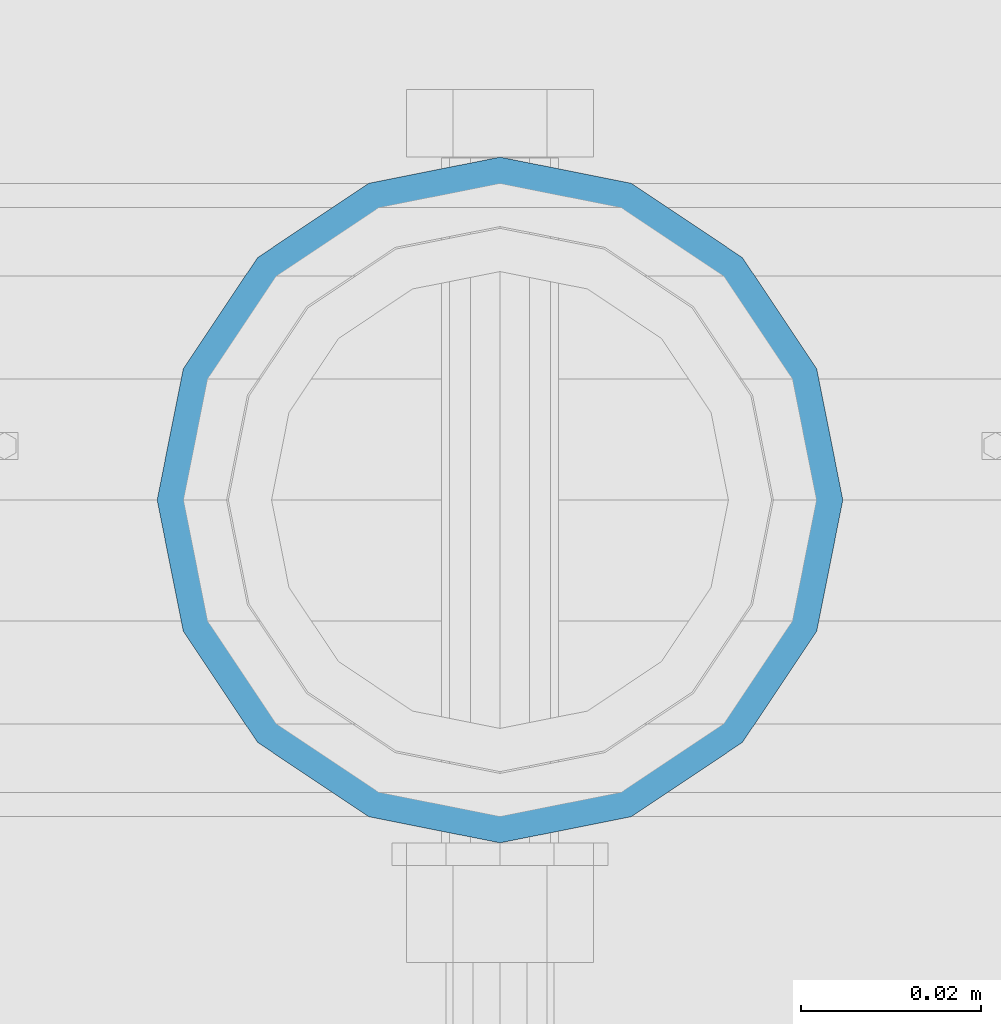
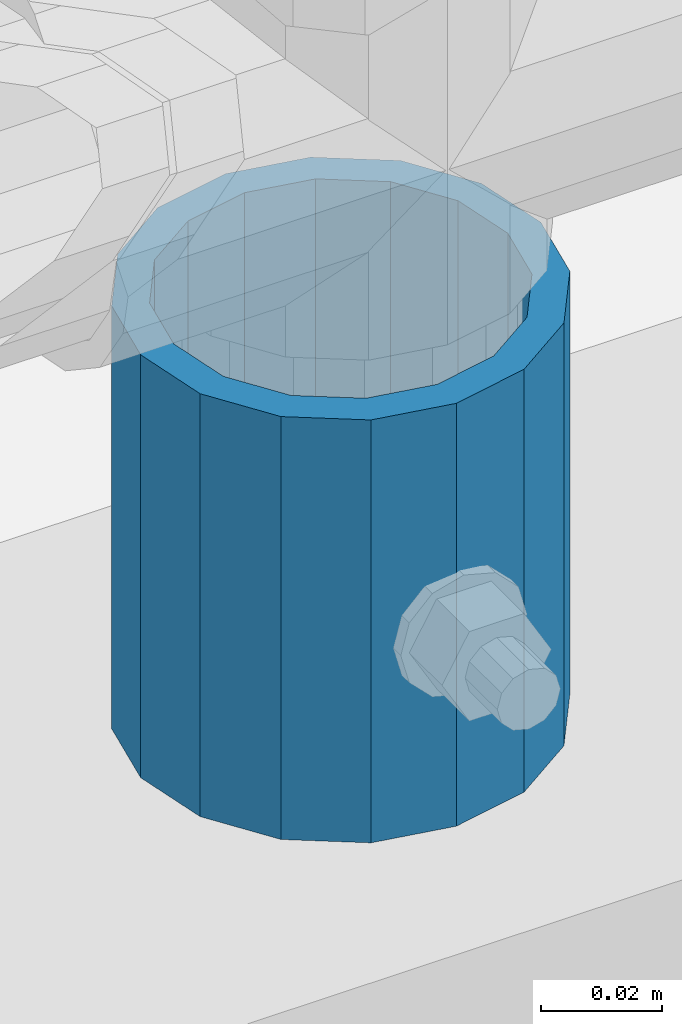
# One storey, part 81 of 242: 1 column.
"""IFC2X3 building model written with IfcOpenShell, lengths in millimetres."""

import ifcopenshell
import ifcopenshell.guid

model = None  # the IFC model being written
_history = None  # IfcOwnerHistory: only IFC2X3 demands one
_inside = {}  # id of a spatial element -> (the spatial element, [elements in it])
_under = {}  # id of a project, library or spatial element -> (it, [spatial elements below it])
_declared = {}  # id of a project -> (the project, [libraries it declares])
_typed = {}  # id of a type object -> (the type object, [elements of that type])
_made_of = {}  # id of a material, layer set ... -> (it, [elements and type objects made of it])


def new_model(schema):
    """Start an empty IFC model of exactly this schema.

    Asked for "IFC4X3", IfcOpenShell would pick the latest addendum, in which some entities
    have other attributes; the version numbers below select the first issue.
    IFC2X3 requires an IfcOwnerHistory on every rooted entity: one is made here for all.
    """
    global model, _history
    if schema == "IFC4X3":
        model = ifcopenshell.file(schema_version=(4, 3, 0, 0))
    else:
        model = ifcopenshell.file(schema=schema)
    _inside.clear()
    _under.clear()
    _declared.clear()
    _typed.clear()
    _made_of.clear()
    _history = None
    if model.schema == "IFC2X3":
        org = make("IfcOrganization", Name="unknown")
        user = make(
            "IfcPersonAndOrganization",
            ThePerson=make("IfcPerson", FamilyName="unknown"),
            TheOrganization=org,
        )
        app = make(
            "IfcApplication",
            ApplicationDeveloper=org,
            Version="unknown",
            ApplicationFullName="unknown",
            ApplicationIdentifier="unknown",
        )
        _history = make(
            "IfcOwnerHistory",
            OwningUser=user,
            OwningApplication=app,
            ChangeAction="ADDED",
            CreationDate=0,
        )
    return model


def make(cls, **values):
    """One entity of the class cls with the attributes given. An attribute that is None is left unset."""
    return model.create_entity(
        cls, **{name: value for name, value in values.items() if value is not None}
    )


def rooted(cls, **values):
    """An entity with a GlobalId (a new one), such as an element, a storey or a relation."""
    return make(cls, GlobalId=ifcopenshell.guid.new(), OwnerHistory=_history, **values)


def si_unit(unit_type, name, prefix=None):
    """IfcSIUnit, for example si_unit("LENGTHUNIT", "METRE", prefix="MILLI")."""
    return make("IfcSIUnit", UnitType=unit_type, Prefix=prefix, Name=name)


def assignment(units):
    """IfcUnitAssignment: the units of a project."""
    return None if units is None else make("IfcUnitAssignment", Units=units)


def point(xyz):
    """IfcCartesianPoint."""
    return None if xyz is None else make("IfcCartesianPoint", Coordinates=xyz)


def direction(xyz):
    """IfcDirection."""
    return None if xyz is None else make("IfcDirection", DirectionRatios=xyz)


def frame(location, z_axis=None, x_axis=None):
    """IfcAxis2Placement3D, a coordinate frame: its origin and axes. An axis left out is left unset."""
    return make(
        "IfcAxis2Placement3D",
        Location=point(location),
        Axis=direction(z_axis),
        RefDirection=direction(x_axis),
    )


def origin_with_axes():
    """The frame at (0, 0, 0) with the z axis (0, 0, 1) and the x axis (1, 0, 0) written out."""
    return frame((0.0, 0.0, 0.0), z_axis=(0.0, 0.0, 1.0), x_axis=(1.0, 0.0, 0.0))


def place(relative_to, where):
    """IfcLocalPlacement: puts the frame where relative to a parent placement (None: the world)."""
    return make(
        "IfcLocalPlacement", PlacementRelTo=relative_to, RelativePlacement=where
    )


def context(
    kind, dimensions, precision=None, world=None, true_north=None, identifier=None
):
    """IfcGeometricRepresentationContext, for example the 3D "Model" context."""
    return make(
        "IfcGeometricRepresentationContext",
        ContextIdentifier=identifier,
        ContextType=kind,
        CoordinateSpaceDimension=dimensions,
        Precision=precision,
        WorldCoordinateSystem=world,
        TrueNorth=true_north,
    )


def subcontext(parent, identifier, kind, view, scale=None):
    """IfcGeometricRepresentationSubContext, for example "Body" below "Model"."""
    return make(
        "IfcGeometricRepresentationSubContext",
        ContextIdentifier=identifier,
        ContextType=kind,
        ParentContext=parent,
        TargetScale=scale,
        TargetView=view,
    )


def project(units=None, contexts=None):
    """IfcProject with its units and contexts."""
    return rooted(
        "IfcProject",
        Name="project",
        RepresentationContexts=contexts,
        UnitsInContext=assignment(units),
    )


def spatial(cls, under=None, at=None, **own):
    """A site, building, storey or space (cls), placed at a placement, below another one or the project."""
    s = rooted(cls, ObjectPlacement=at, **own)
    if under is not None:
        _under.setdefault(under.id(), (under, []))[1].append(s)
    return s


def faces_of(points, faces, orient=None, outer=None):
    """IfcFace entities. A face is a list of loops; a loop is a list of indices into points, from 0.

    orient and outer hold one flag for each loop. By default every Orientation is true, the
    first loop of a face is its IfcFaceOuterBound and the others are IfcFaceBound.
    """
    made = []
    for i, loops in enumerate(faces):
        bounds = []
        for j, loop in enumerate(loops):
            is_outer = j == 0 if outer is None else outer[i][j]
            bounds.append(
                make(
                    "IfcFaceOuterBound" if is_outer else "IfcFaceBound",
                    Bound=make("IfcPolyLoop", Polygon=[points[k] for k in loop]),
                    Orientation=True if orient is None else orient[i][j],
                )
            )
        made.append(make("IfcFace", Bounds=bounds))
    return made


def faceted_brep(points, faces, orient=None, outer=None, voids=None):
    """IfcFacetedBrep: a solid bounded by flat faces; with voids (closed shells), ...WithVoids."""
    shared = [point(p) for p in points]
    hull = make("IfcClosedShell", CfsFaces=faces_of(shared, faces, orient, outer))
    if voids is None:
        return make("IfcFacetedBrep", Outer=hull)
    return make(
        "IfcFacetedBrepWithVoids",
        Outer=hull,
        Voids=[
            make(cls, CfsFaces=faces_of(shared, fs, o, b)) for cls, fs, o, b in voids
        ],
    )


def shape(context_of_items, identifier, shape_type, items):
    """IfcShapeRepresentation: the items that make up one representation, for example the "Body"."""
    return make(
        "IfcShapeRepresentation",
        ContextOfItems=context_of_items,
        RepresentationIdentifier=identifier,
        RepresentationType=shape_type,
        Items=items,
    )


def material(Name=None, Category=None):
    """IfcMaterial."""
    return make("IfcMaterial", Name=Name, Category=Category)


def made_of(thing, what):
    """Note that an element or type object is made of a material, layer set ...; save() writes the relation."""
    if what is not None:
        _made_of.setdefault(what.id(), (what, []))[1].append(thing)
    return thing


def type_object(cls, material=None, **own):
    """A type object (cls), such as IfcWallType, which elements share."""
    return made_of(rooted(cls, **own), material)


def element(
    cls,
    number,
    at=None,
    inside=None,
    cuts=None,
    type_object=None,
    material=None,
    context=None,
    identifier="Body",
    shape_type=None,
    held_by="IfcProductDefinitionShape",
    body=None,
    shapes=None,
    **own,
):
    """One element of the class cls, such as IfcWall. Its Tag is "e" and its number.

    at: its placement. inside: the storey or other place that contains it. cuts: it is an
    opening in that element (IfcRelVoidsElement). A single representation is given by context,
    identifier, shape_type and body (its items); several are given by shapes. held_by: the class
    of the entity that holds the representations. save() writes the other relations.
    """
    e = rooted(cls, Tag="e%d" % number, ObjectPlacement=at, **own)
    if body is not None:
        shapes = [shape(context, identifier, shape_type, body)]
    if shapes is not None:
        e.Representation = make(held_by, Representations=shapes)
    if inside is not None:
        _inside.setdefault(inside.id(), (inside, []))[1].append(e)
    if cuts is not None:
        rooted(
            "IfcRelVoidsElement", RelatingBuildingElement=cuts, RelatedOpeningElement=e
        )
    if type_object is not None:
        _typed.setdefault(type_object.id(), (type_object, []))[1].append(e)
    return made_of(e, material)


def aggregate(whole, parts):
    """IfcRelAggregates: a whole, such as a stair, and the parts it consists of."""
    return rooted("IfcRelAggregates", RelatingObject=whole, RelatedObjects=parts)


def save(model, path):
    """Write the relations noted so far, then the file.

    IfcRelAggregates (storeys below a building ...), IfcRelContainedInSpatialStructure (elements
    in a storey), IfcRelDefinesByType, IfcRelAssociatesMaterial and IfcRelDeclares: one each for
    every whole, place, type object, material and project.
    """
    for whole, parts in _under.values():
        aggregate(whole, parts)
    for where, things in _inside.values():
        rooted(
            "IfcRelContainedInSpatialStructure",
            RelatedElements=things,
            RelatingStructure=where,
        )
    for kind, things in _typed.values():
        rooted("IfcRelDefinesByType", RelatedObjects=things, RelatingType=kind)
    for what, things in _made_of.values():
        rooted("IfcRelAssociatesMaterial", RelatedObjects=things, RelatingMaterial=what)
    for by, libraries in _declared.values():
        rooted("IfcRelDeclares", RelatingContext=by, RelatedDefinitions=libraries)
    model.write(path)


model = new_model("IFC2X3")

# Units and contexts
model_context = context("Model", 3, precision=1e-05, world=origin_with_axes())
body_context = subcontext(model_context, "Body", "Model", "MODEL_VIEW")
ifc_project = project(units=[si_unit("LENGTHUNIT", "METRE", prefix="MILLI"), si_unit("AREAUNIT", "SQUARE_METRE"), si_unit("VOLUMEUNIT", "CUBIC_METRE"), si_unit("MASSUNIT", "GRAM", prefix="KILO"), si_unit("TIMEUNIT", "SECOND"), si_unit("PLANEANGLEUNIT", "RADIAN"), si_unit("SOLIDANGLEUNIT", "STERADIAN"), si_unit("THERMODYNAMICTEMPERATUREUNIT", "DEGREE_CELSIUS"), si_unit("LUMINOUSINTENSITYUNIT", "LUMEN")], contexts=[model_context])

# Site, building, storey
site_placement = place(None, origin_with_axes())
site = spatial("IfcSite", under=ifc_project, at=site_placement, CompositionType="ELEMENT")
building_placement = place(site_placement, origin_with_axes())
building = spatial("IfcBuilding", under=site, at=building_placement, Name="Standard", CompositionType="ELEMENT")
storey_placement = place(building_placement, origin_with_axes())
storey = spatial("IfcBuildingStorey", under=building, at=storey_placement, Name="Undefined", CompositionType="ELEMENT", Elevation=0.0)

# Column
ifc_material = material()
column_type = type_object("IfcColumnType", PredefinedType="NOTDEFINED")
column_placement = place(storey_placement, frame((-33664.0, -19335.5, 168.02), z_axis=(0.0, 1.0, 0.0), x_axis=(0.0, 0.0, 1.0)))
element("IfcColumn", 1, at=column_placement, inside=storey, type_object=column_type, material=ifc_material, context=body_context, shape_type="Brep", body=[
    faceted_brep([(0.0, -31.75, 0.0), (0.0, -29.3331751572332, 12.1501989775934), (85.0, -29.3331751572332, 12.1501989775934), (85.0, -31.75, 0.0), (0.0, -22.4506403026717, 22.4506403026717), (85.0, -22.4506403026717, 22.4506403026717), (0.0, -12.1501989775934, 29.3331751572332), (85.0, -12.1501989775934, 29.3331751572332), (0.0, 0.0, 31.75), (85.0, 0.0, 31.75), (0.0, 12.1501989775934, 29.3331751572332), (85.0, 12.1501989775934, 29.3331751572332), (0.0, 22.4506403026717, 22.4506403026717), (85.0, 22.4506403026717, 22.4506403026717), (0.0, 29.3331751572332, 12.1501989775934), (85.0, 29.3331751572332, 12.1501989775934), (0.0, 31.75, 0.0), (85.0, 31.75, 0.0), (0.0, 29.3331751572332, -12.1501989775934), (85.0, 29.3331751572332, -12.1501989775934), (0.0, 22.4506403026717, -22.4506403026717), (85.0, 22.4506403026717, -22.4506403026717), (0.0, 12.1501989775934, -29.3331751572332), (85.0, 12.1501989775934, -29.3331751572332), (0.0, 0.0, -31.75), (85.0, 0.0, -31.75), (0.0, -12.1501989775934, -29.3331751572332), (85.0, -12.1501989775934, -29.3331751572332), (0.0, -22.4506403026717, -22.4506403026717), (85.0, -22.4506403026717, -22.4506403026717), (0.0, -29.3331751572332, -12.1501989775934), (85.0, -29.3331751572332, -12.1501989775934), (0.0, -38.0499999999993, 0.0), (0.0, -35.1536162120537, -14.5611046014928), (85.0, -35.1536162120537, -14.5611046014928), (85.0, -38.0499999999993, 0.0), (0.0, -26.9054130241493, -26.9054130241493), (85.0, -26.9054130241493, -26.9054130241493), (0.0, -14.5611046014928, -35.1536162120537), (85.0, -14.5611046014928, -35.1536162120537), (0.0, 0.0, -38.0499999999993), (85.0, 0.0, -38.0499999999993), (0.0, 14.5611046014928, -35.1536162120537), (85.0, 14.5611046014928, -35.1536162120537), (0.0, 26.9054130241493, -26.9054130241493), (85.0, 26.9054130241493, -26.9054130241493), (0.0, 35.1536162120537, -14.5611046014928), (85.0, 35.1536162120537, -14.5611046014928), (0.0, 38.0499999999993, 0.0), (85.0, 38.0499999999993, 0.0), (0.0, 35.1536162120537, 14.5611046014928), (85.0, 35.1536162120537, 14.5611046014928), (0.0, 26.9054130241493, 26.9054130241493), (85.0, 26.9054130241493, 26.9054130241493), (0.0, 14.5611046014928, 35.1536162120537), (85.0, 14.5611046014928, 35.1536162120537), (0.0, 0.0, 38.0499999999993), (85.0, 0.0, 38.0499999999993), (0.0, -14.5611046014928, 35.1536162120537), (85.0, -14.5611046014928, 35.1536162120537), (0.0, -26.9054130241493, 26.9054130241493), (85.0, -26.9054130241493, 26.9054130241493), (0.0, -35.1536162120537, 14.5611046014928), (85.0, -35.1536162120537, 14.5611046014928)], [[[0, 1, 2, 3]], [[1, 4, 5, 2]], [[4, 6, 7, 5]], [[6, 8, 9, 7]], [[8, 10, 11, 9]], [[10, 12, 13, 11]], [[12, 14, 15, 13]], [[14, 16, 17, 15]], [[16, 18, 19, 17]], [[18, 20, 21, 19]], [[20, 22, 23, 21]], [[22, 24, 25, 23]], [[24, 26, 27, 25]], [[26, 28, 29, 27]], [[28, 30, 31, 29]], [[30, 0, 3, 31]], [[32, 33, 34, 35]], [[33, 36, 37, 34]], [[36, 38, 39, 37]], [[38, 40, 41, 39]], [[40, 42, 43, 41]], [[42, 44, 45, 43]], [[44, 46, 47, 45]], [[46, 48, 49, 47]], [[48, 50, 51, 49]], [[50, 52, 53, 51]], [[52, 54, 55, 53]], [[54, 56, 57, 55]], [[56, 58, 59, 57]], [[58, 60, 61, 59]], [[60, 62, 63, 61]], [[62, 32, 35, 63]], [[37, 39, 41, 43, 45, 47, 49, 51, 53, 55, 57, 59, 61, 63, 35, 34], [5, 7, 9, 11, 13, 15, 17, 19, 21, 23, 25, 27, 29, 31, 3, 2]], [[62, 60, 58, 56, 54, 52, 50, 48, 46, 44, 42, 40, 38, 36, 33, 32], [30, 28, 26, 24, 22, 20, 18, 16, 14, 12, 10, 8, 6, 4, 1, 0]]]),
])

save(model, "model.ifc")
